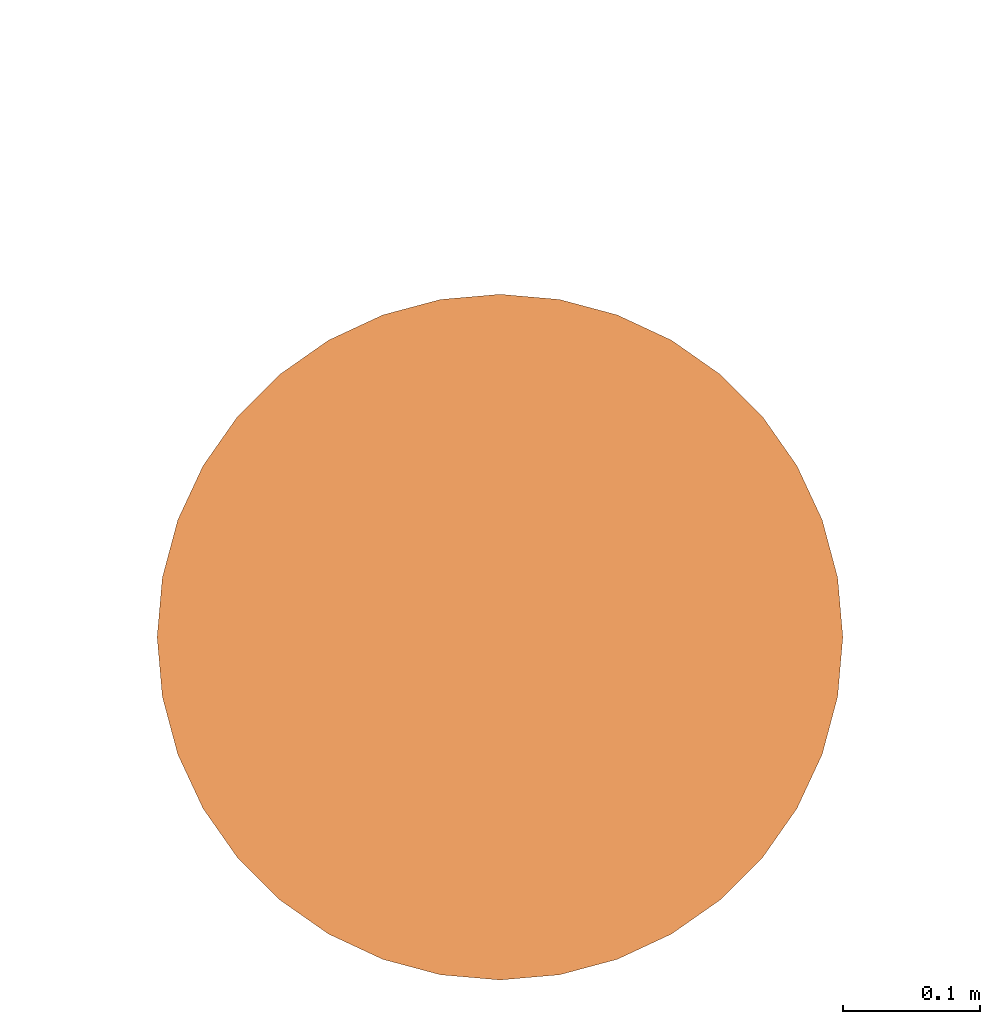
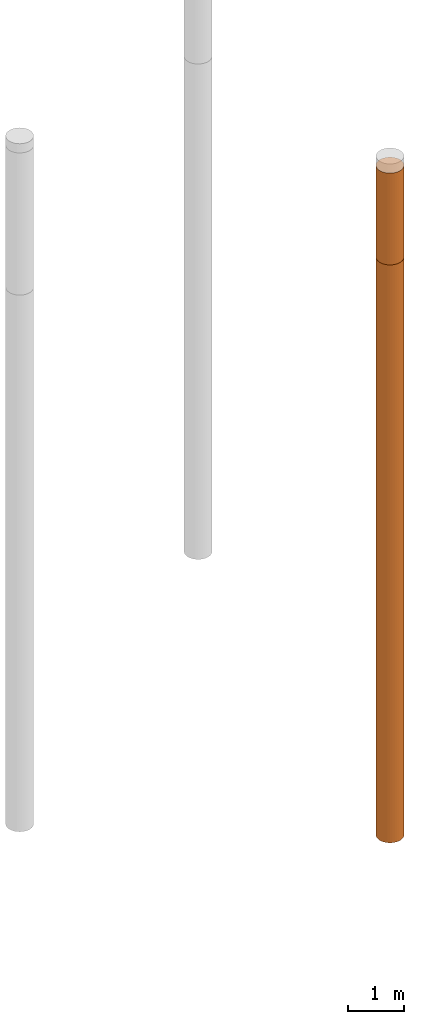
# One storey, part 3 of 8: 2 proxies.
"""IFC4 building model written with IfcOpenShell, lengths in metres."""

from ifc_helpers import new_model, entity, si_unit, converted_unit, frame, origin, place, context, subcontext, project, spatial, faceted_brep, material, element, save


model = new_model("IFC4")

# Units and contexts
model_context = context("Model", 3, precision=1e-05, world=origin())
body_context = subcontext(model_context, "Body", "Model", "MODEL_VIEW")
ifc_project = project(units=[si_unit("LENGTHUNIT", "METRE"), si_unit("AREAUNIT", "SQUARE_METRE"), si_unit("VOLUMEUNIT", "CUBIC_METRE"), converted_unit("PLANEANGLEUNIT", "DEGREE", entity("IfcPlaneAngleMeasure", 0.0174532925199433), si_unit("PLANEANGLEUNIT", "RADIAN"), dimensions=[0, 0, 0, 0, 0, 0, 0])], contexts=[model_context])

# Site, building, storey
site_placement = place(None, origin())
site = spatial("IfcSite", under=ifc_project, at=site_placement, CompositionType="ELEMENT")
building_placement = place(site_placement, origin())
building = spatial("IfcBuilding", under=site, at=building_placement, Name="Demo", CompositionType="ELEMENT")
storey_placement = place(building_placement, origin())
storey = spatial("IfcBuildingStorey", under=building, at=storey_placement, Name="Boden", CompositionType="ELEMENT", Elevation=0.0)

# Proxies
ifc_material_1 = material()
proxy_1_placement = place(storey_placement, frame((15.17, 5.39, -2.0)))
element("IfcBuildingElementProxy", 1, at=proxy_1_placement, inside=storey, material=ifc_material_1, Name="KB-02_Sand", PredefinedType="USERDEFINED", context=body_context, shape_type="Brep", body=[
    faceted_brep([(0.4962019382530525, 0.2934120444167338, 2.0), (0.5, 0.25, 2.0), (0.4962019382530525, 0.2065879555832671, 2.0), (0.4849231551964767, 0.1644949641685826, 2.0), (0.4665063509461107, 0.125, 2.0), (0.4415111107797439, 0.08930309757836494, 2.0), (0.4106969024216342, 0.05848888922025526, 2.0), (0.375, 0.0334936490538903, 2.0), (0.3355050358314166, 0.01507684480352327, 2.0), (0.2934120444167329, 0.003798061746948406, 2.0), (0.25, 0.0, 2.0), (0.2065879555832671, 0.003798061746948406, 2.0), (0.1644949641685835, 0.01507684480352327, 2.0), (0.125, 0.0334936490538903, 2.0), (0.08930309757836585, 0.05848888922025526, 2.0), (0.05848888922025617, 0.08930309757836494, 2.0), (0.0334936490538912, 0.125, 2.0), (0.01507684480352327, 0.1644949641685826, 2.0), (0.003798061746947497, 0.2065879555832671, 2.0), (0.0, 0.25, 2.0), (0.003798061746947497, 0.293412044416732, 2.0), (0.01507684480352327, 0.3355050358314166, 2.0), (0.03349364905388939, 0.375, 2.0), (0.05848888922025435, 0.4106969024216342, 2.0), (0.08930309757836404, 0.4415111107797439, 2.0), (0.125, 0.4665063509461097, 2.0), (0.1644949641685816, 0.4849231551964767, 2.0), (0.2065879555832671, 0.4962019382530516, 2.0), (0.25, 0.5, 2.0), (0.2934120444167311, 0.4962019382530525, 2.0), (0.3355050358314166, 0.4849231551964777, 2.0), (0.375, 0.4665063509461097, 2.0), (0.4106969024216342, 0.4415111107797448, 2.0), (0.4415111107797439, 0.410696902421636, 2.0), (0.4665063509461088, 0.3750000000000009, 2.0), (0.4849231551964767, 0.3355050358314184, 2.0), (0.5, 0.25, 0.0), (0.4962019382530525, 0.2934120444167338, 0.0), (0.4849231551964767, 0.3355050358314184, 0.0), (0.4665063509461088, 0.3750000000000009, 0.0), (0.4415111107797439, 0.4106969024216351, 0.0), (0.4106969024216342, 0.4415111107797448, 0.0), (0.375, 0.4665063509461097, 0.0), (0.3355050358314166, 0.4849231551964767, 0.0), (0.2934120444167311, 0.4962019382530516, 0.0), (0.25, 0.5, 0.0), (0.2065879555832671, 0.4962019382530516, 0.0), (0.1644949641685816, 0.4849231551964767, 0.0), (0.125, 0.4665063509461088, 0.0), (0.08930309757836404, 0.4415111107797439, 0.0), (0.05848888922025435, 0.4106969024216342, 0.0), (0.03349364905388939, 0.3749999999999991, 0.0), (0.01507684480352327, 0.3355050358314166, 0.0), (0.003798061746947497, 0.293412044416732, 0.0), (0.0, 0.2499999999999991, 0.0), (0.003798061746947497, 0.2065879555832671, 0.0), (0.01507684480352327, 0.1644949641685826, 0.0), (0.0334936490538912, 0.125, 0.0), (0.05848888922025617, 0.08930309757836494, 0.0), (0.08930309757836585, 0.05848888922025526, 0.0), (0.125, 0.0334936490538903, 0.0), (0.1644949641685835, 0.01507684480352236, 0.0), (0.2065879555832671, 0.003798061746947497, 0.0), (0.25, 0.0, 0.0), (0.2934120444167329, 0.003798061746947497, 0.0), (0.3355050358314166, 0.01507684480352236, 0.0), (0.375, 0.0334936490538903, 0.0), (0.4106969024216342, 0.05848888922025526, 0.0), (0.4415111107797439, 0.08930309757836494, 0.0), (0.4665063509461107, 0.125, 0.0), (0.4849231551964767, 0.1644949641685826, 0.0), (0.4962019382530525, 0.2065879555832671, 0.0), (0.5, 0.25, 2.0), (0.4962019382530525, 0.2934120444167338, 2.0), (0.4962019382530525, 0.2934120444167338, 0.0), (0.5, 0.25, 0.0), (0.4962019382530525, 0.2065879555832671, 2.0), (0.5, 0.25, 2.0), (0.5, 0.25, 0.0), (0.4962019382530525, 0.2065879555832671, 0.0), (0.4849231551964767, 0.1644949641685826, 2.0), (0.4962019382530525, 0.2065879555832671, 2.0), (0.4962019382530525, 0.2065879555832671, 0.0), (0.4849231551964767, 0.1644949641685826, 0.0), (0.4665063509461107, 0.125, 2.0), (0.4849231551964767, 0.1644949641685826, 2.0), (0.4849231551964767, 0.1644949641685826, 0.0), (0.4665063509461107, 0.125, 0.0), (0.4415111107797439, 0.08930309757836494, 2.0), (0.4665063509461107, 0.125, 2.0), (0.4665063509461107, 0.125, 0.0), (0.4415111107797439, 0.08930309757836494, 0.0), (0.4106969024216342, 0.05848888922025526, 2.0), (0.4415111107797439, 0.08930309757836494, 2.0), (0.4415111107797439, 0.08930309757836494, 0.0), (0.4106969024216342, 0.05848888922025526, 0.0), (0.375, 0.0334936490538903, 2.0), (0.4106969024216342, 0.05848888922025526, 2.0), (0.4106969024216342, 0.05848888922025526, 0.0), (0.375, 0.0334936490538903, 0.0), (0.3355050358314166, 0.01507684480352327, 2.0), (0.375, 0.0334936490538903, 2.0), (0.375, 0.0334936490538903, 0.0), (0.3355050358314166, 0.01507684480352236, 0.0), (0.2934120444167329, 0.003798061746948406, 2.0), (0.3355050358314166, 0.01507684480352327, 2.0), (0.3355050358314166, 0.01507684480352236, 0.0), (0.2934120444167329, 0.003798061746947497, 0.0), (0.25, 0.0, 2.0), (0.2934120444167329, 0.003798061746948406, 2.0), (0.2934120444167329, 0.003798061746947497, 0.0), (0.25, 0.0, 0.0), (0.2065879555832671, 0.003798061746948406, 2.0), (0.25, 0.0, 2.0), (0.25, 0.0, 0.0), (0.2065879555832671, 0.003798061746947497, 0.0), (0.1644949641685835, 0.01507684480352327, 2.0), (0.2065879555832671, 0.003798061746948406, 2.0), (0.2065879555832671, 0.003798061746947497, 0.0), (0.1644949641685835, 0.01507684480352236, 0.0), (0.125, 0.0334936490538903, 2.0), (0.1644949641685835, 0.01507684480352327, 2.0), (0.1644949641685835, 0.01507684480352236, 0.0), (0.125, 0.0334936490538903, 0.0), (0.08930309757836585, 0.05848888922025526, 2.0), (0.125, 0.0334936490538903, 2.0), (0.125, 0.0334936490538903, 0.0), (0.08930309757836585, 0.05848888922025526, 0.0), (0.05848888922025617, 0.08930309757836494, 2.0), (0.08930309757836585, 0.05848888922025526, 2.0), (0.08930309757836585, 0.05848888922025526, 0.0), (0.05848888922025617, 0.08930309757836494, 0.0), (0.0334936490538912, 0.125, 2.0), (0.05848888922025617, 0.08930309757836494, 2.0), (0.05848888922025617, 0.08930309757836494, 0.0), (0.0334936490538912, 0.125, 0.0), (0.01507684480352327, 0.1644949641685826, 2.0), (0.0334936490538912, 0.125, 2.0), (0.0334936490538912, 0.125, 0.0), (0.01507684480352327, 0.1644949641685826, 0.0), (0.003798061746947497, 0.2065879555832671, 2.0), (0.01507684480352327, 0.1644949641685826, 2.0), (0.01507684480352327, 0.1644949641685826, 0.0), (0.003798061746947497, 0.2065879555832671, 0.0), (0.0, 0.25, 2.0), (0.003798061746947497, 0.2065879555832671, 2.0), (0.003798061746947497, 0.2065879555832671, 0.0), (0.0, 0.2499999999999991, 0.0), (0.003798061746947497, 0.293412044416732, 2.0), (0.0, 0.25, 2.0), (0.0, 0.2499999999999991, 0.0), (0.003798061746947497, 0.293412044416732, 0.0), (0.01507684480352327, 0.3355050358314166, 2.0), (0.003798061746947497, 0.293412044416732, 2.0), (0.003798061746947497, 0.293412044416732, 0.0), (0.01507684480352327, 0.3355050358314166, 0.0), (0.03349364905388939, 0.375, 2.0), (0.01507684480352327, 0.3355050358314166, 2.0), (0.01507684480352327, 0.3355050358314166, 0.0), (0.03349364905388939, 0.3749999999999991, 0.0), (0.05848888922025435, 0.4106969024216342, 2.0), (0.03349364905388939, 0.375, 2.0), (0.03349364905388939, 0.3749999999999991, 0.0), (0.05848888922025435, 0.4106969024216342, 0.0), (0.08930309757836404, 0.4415111107797439, 2.0), (0.05848888922025435, 0.4106969024216342, 2.0), (0.05848888922025435, 0.4106969024216342, 0.0), (0.08930309757836404, 0.4415111107797439, 0.0), (0.125, 0.4665063509461097, 2.0), (0.08930309757836404, 0.4415111107797439, 2.0), (0.08930309757836404, 0.4415111107797439, 0.0), (0.125, 0.4665063509461088, 0.0), (0.1644949641685816, 0.4849231551964767, 2.0), (0.125, 0.4665063509461097, 2.0), (0.125, 0.4665063509461088, 0.0), (0.1644949641685816, 0.4849231551964767, 0.0), (0.2065879555832671, 0.4962019382530516, 2.0), (0.1644949641685816, 0.4849231551964767, 2.0), (0.1644949641685816, 0.4849231551964767, 0.0), (0.2065879555832671, 0.4962019382530516, 0.0), (0.25, 0.5, 2.0), (0.2065879555832671, 0.4962019382530516, 2.0), (0.2065879555832671, 0.4962019382530516, 0.0), (0.25, 0.5, 0.0), (0.2934120444167311, 0.4962019382530525, 2.0), (0.25, 0.5, 2.0), (0.25, 0.5, 0.0), (0.2934120444167311, 0.4962019382530516, 0.0), (0.3355050358314166, 0.4849231551964777, 2.0), (0.2934120444167311, 0.4962019382530525, 2.0), (0.2934120444167311, 0.4962019382530516, 0.0), (0.3355050358314166, 0.4849231551964767, 0.0), (0.375, 0.4665063509461097, 2.0), (0.3355050358314166, 0.4849231551964777, 2.0), (0.3355050358314166, 0.4849231551964767, 0.0), (0.375, 0.4665063509461097, 0.0), (0.4106969024216342, 0.4415111107797448, 2.0), (0.375, 0.4665063509461097, 2.0), (0.375, 0.4665063509461097, 0.0), (0.4106969024216342, 0.4415111107797448, 0.0), (0.4415111107797439, 0.410696902421636, 2.0), (0.4106969024216342, 0.4415111107797448, 2.0), (0.4106969024216342, 0.4415111107797448, 0.0), (0.4415111107797439, 0.4106969024216351, 0.0), (0.4665063509461088, 0.3750000000000009, 2.0), (0.4415111107797439, 0.410696902421636, 2.0), (0.4415111107797439, 0.4106969024216351, 0.0), (0.4665063509461088, 0.3750000000000009, 0.0), (0.4849231551964767, 0.3355050358314184, 2.0), (0.4665063509461088, 0.3750000000000009, 2.0), (0.4665063509461088, 0.3750000000000009, 0.0), (0.4849231551964767, 0.3355050358314184, 0.0), (0.4962019382530525, 0.2934120444167338, 2.0), (0.4849231551964767, 0.3355050358314184, 2.0), (0.4849231551964767, 0.3355050358314184, 0.0), (0.4962019382530525, 0.2934120444167338, 0.0)], [[[0, 1, 2, 3, 4, 5, 6, 7, 8, 9, 10, 11, 12, 13, 14, 15, 16, 17, 18, 19, 20, 21, 22, 23, 24, 25, 26, 27, 28, 29, 30, 31, 32, 33, 34, 35]], [[36, 37, 38, 39, 40, 41, 42, 43, 44, 45, 46, 47, 48, 49, 50, 51, 52, 53, 54, 55, 56, 57, 58, 59, 60, 61, 62, 63, 64, 65, 66, 67, 68, 69, 70, 71]], [[72, 73, 74, 75]], [[76, 77, 78, 79]], [[80, 81, 82, 83]], [[84, 85, 86, 87]], [[88, 89, 90, 91]], [[92, 93, 94, 95]], [[96, 97, 98, 99]], [[100, 101, 102, 103]], [[104, 105, 106, 107]], [[108, 109, 110, 111]], [[112, 113, 114, 115]], [[116, 117, 118, 119]], [[120, 121, 122, 123]], [[124, 125, 126, 127]], [[128, 129, 130, 131]], [[132, 133, 134, 135]], [[136, 137, 138, 139]], [[140, 141, 142, 143]], [[144, 145, 146, 147]], [[148, 149, 150, 151]], [[152, 153, 154, 155]], [[156, 157, 158, 159]], [[160, 161, 162, 163]], [[164, 165, 166, 167]], [[168, 169, 170, 171]], [[172, 173, 174, 175]], [[176, 177, 178, 179]], [[180, 181, 182, 183]], [[184, 185, 186, 187]], [[188, 189, 190, 191]], [[192, 193, 194, 195]], [[196, 197, 198, 199]], [[200, 201, 202, 203]], [[204, 205, 206, 207]], [[208, 209, 210, 211]], [[212, 213, 214, 215]]], orient=[[False], [False], [False], [False], [False], [False], [False], [False], [False], [False], [False], [False], [False], [False], [False], [False], [False], [False], [False], [False], [False], [False], [False], [False], [False], [False], [False], [False], [False], [False], [False], [False], [False], [False], [False], [False], [False], [False]]),
])
ifc_material_2 = material()
proxy_2_placement = place(storey_placement, frame((15.17, 5.389999999999998, -14.6)))
element("IfcBuildingElementProxy", 2, at=proxy_2_placement, inside=storey, material=ifc_material_2, Name="KB-02_Kies", PredefinedType="USERDEFINED", context=body_context, shape_type="Brep", body=[
    faceted_brep([(0.4962019382530525, 0.2934120444167356, 12.6), (0.5, 0.2500000000000018, 12.6), (0.4962019382530525, 0.2065879555832689, 12.6), (0.4849231551964767, 0.1644949641685844, 12.6), (0.4665063509461107, 0.1250000000000018, 12.6), (0.4415111107797439, 0.08930309757836676, 12.6), (0.4106969024216342, 0.05848888922025708, 12.6), (0.375, 0.03349364905389211, 12.6), (0.3355050358314166, 0.01507684480352509, 12.6), (0.2934120444167329, 0.003798061746950225, 12.6), (0.25, 1.818989403545857e-15, 12.6), (0.2065879555832671, 0.003798061746950225, 12.6), (0.1644949641685835, 0.01507684480352509, 12.6), (0.125, 0.03349364905389211, 12.6), (0.08930309757836585, 0.05848888922025708, 12.6), (0.05848888922025617, 0.08930309757836676, 12.6), (0.0334936490538912, 0.1250000000000018, 12.6), (0.01507684480352327, 0.1644949641685844, 12.6), (0.003798061746947497, 0.2065879555832689, 12.6), (0.0, 0.2500000000000018, 12.6), (0.003798061746947497, 0.2934120444167338, 12.6), (0.01507684480352327, 0.3355050358314184, 12.6), (0.03349364905388939, 0.3750000000000018, 12.6), (0.05848888922025435, 0.410696902421636, 12.6), (0.08930309757836404, 0.4415111107797456, 12.6), (0.125, 0.4665063509461115, 12.6), (0.1644949641685816, 0.4849231551964786, 12.6), (0.2065879555832671, 0.4962019382530534, 12.6), (0.25, 0.5000000000000018, 12.6), (0.2934120444167311, 0.4962019382530543, 12.6), (0.3355050358314166, 0.4849231551964795, 12.6), (0.375, 0.4665063509461115, 12.6), (0.4106969024216342, 0.4415111107797466, 12.6), (0.4415111107797439, 0.4106969024216378, 12.6), (0.4665063509461088, 0.3750000000000027, 12.6), (0.4849231551964767, 0.3355050358314202, 12.6), (0.5, 0.25, 0.0), (0.4962019382530525, 0.2934120444167338, 0.0), (0.4849231551964767, 0.3355050358314184, 0.0), (0.4665063509461088, 0.3750000000000009, 0.0), (0.4415111107797439, 0.410696902421636, 0.0), (0.4106969024216342, 0.4415111107797456, 0.0), (0.375, 0.4665063509461107, 0.0), (0.3355050358314166, 0.4849231551964777, 0.0), (0.2934120444167311, 0.4962019382530525, 0.0), (0.25, 0.5, 0.0), (0.2065879555832671, 0.4962019382530525, 0.0), (0.1644949641685816, 0.4849231551964767, 0.0), (0.125, 0.4665063509461097, 0.0), (0.08930309757836404, 0.4415111107797448, 0.0), (0.05848888922025435, 0.4106969024216351, 0.0), (0.03349364905388939, 0.375, 0.0), (0.01507684480352327, 0.3355050358314174, 0.0), (0.003798061746947497, 0.2934120444167329, 0.0), (0.0, 0.25, 0.0), (0.003798061746947497, 0.2065879555832671, 0.0), (0.01507684480352327, 0.1644949641685826, 0.0), (0.0334936490538912, 0.125, 0.0), (0.05848888922025617, 0.08930309757836494, 0.0), (0.08930309757836585, 0.05848888922025526, 0.0), (0.125, 0.0334936490538903, 0.0), (0.1644949641685835, 0.01507684480352327, 0.0), (0.2065879555832671, 0.003798061746948406, 0.0), (0.25, 0.0, 0.0), (0.2934120444167329, 0.003798061746948406, 0.0), (0.3355050358314166, 0.01507684480352327, 0.0), (0.375, 0.0334936490538903, 0.0), (0.4106969024216342, 0.05848888922025617, 0.0), (0.4415111107797439, 0.08930309757836585, 0.0), (0.4665063509461107, 0.125, 0.0), (0.4849231551964767, 0.1644949641685835, 0.0), (0.4962019382530525, 0.206587955583268, 0.0), (0.5, 0.2500000000000018, 12.6), (0.4962019382530525, 0.2934120444167356, 12.6), (0.4962019382530525, 0.2934120444167338, 0.0), (0.5, 0.25, 0.0), (0.4962019382530525, 0.2065879555832689, 12.6), (0.5, 0.2500000000000018, 12.6), (0.5, 0.25, 0.0), (0.4962019382530525, 0.206587955583268, 0.0), (0.4849231551964767, 0.1644949641685844, 12.6), (0.4962019382530525, 0.2065879555832689, 12.6), (0.4962019382530525, 0.206587955583268, 0.0), (0.4849231551964767, 0.1644949641685835, 0.0), (0.4665063509461107, 0.1250000000000018, 12.6), (0.4849231551964767, 0.1644949641685844, 12.6), (0.4849231551964767, 0.1644949641685835, 0.0), (0.4665063509461107, 0.125, 0.0), (0.4415111107797439, 0.08930309757836676, 12.6), (0.4665063509461107, 0.1250000000000018, 12.6), (0.4665063509461107, 0.125, 0.0), (0.4415111107797439, 0.08930309757836585, 0.0), (0.4106969024216342, 0.05848888922025708, 12.6), (0.4415111107797439, 0.08930309757836676, 12.6), (0.4415111107797439, 0.08930309757836585, 0.0), (0.4106969024216342, 0.05848888922025617, 0.0), (0.375, 0.03349364905389211, 12.6), (0.4106969024216342, 0.05848888922025708, 12.6), (0.4106969024216342, 0.05848888922025617, 0.0), (0.375, 0.0334936490538903, 0.0), (0.3355050358314166, 0.01507684480352509, 12.6), (0.375, 0.03349364905389211, 12.6), (0.375, 0.0334936490538903, 0.0), (0.3355050358314166, 0.01507684480352327, 0.0), (0.2934120444167329, 0.003798061746950225, 12.6), (0.3355050358314166, 0.01507684480352509, 12.6), (0.3355050358314166, 0.01507684480352327, 0.0), (0.2934120444167329, 0.003798061746948406, 0.0), (0.25, 1.818989403545857e-15, 12.6), (0.2934120444167329, 0.003798061746950225, 12.6), (0.2934120444167329, 0.003798061746948406, 0.0), (0.25, 0.0, 0.0), (0.2065879555832671, 0.003798061746950225, 12.6), (0.25, 1.818989403545857e-15, 12.6), (0.25, 0.0, 0.0), (0.2065879555832671, 0.003798061746948406, 0.0), (0.1644949641685835, 0.01507684480352509, 12.6), (0.2065879555832671, 0.003798061746950225, 12.6), (0.2065879555832671, 0.003798061746948406, 0.0), (0.1644949641685835, 0.01507684480352327, 0.0), (0.125, 0.03349364905389211, 12.6), (0.1644949641685835, 0.01507684480352509, 12.6), (0.1644949641685835, 0.01507684480352327, 0.0), (0.125, 0.0334936490538903, 0.0), (0.08930309757836585, 0.05848888922025708, 12.6), (0.125, 0.03349364905389211, 12.6), (0.125, 0.0334936490538903, 0.0), (0.08930309757836585, 0.05848888922025526, 0.0), (0.05848888922025617, 0.08930309757836676, 12.6), (0.08930309757836585, 0.05848888922025708, 12.6), (0.08930309757836585, 0.05848888922025526, 0.0), (0.05848888922025617, 0.08930309757836494, 0.0), (0.0334936490538912, 0.1250000000000018, 12.6), (0.05848888922025617, 0.08930309757836676, 12.6), (0.05848888922025617, 0.08930309757836494, 0.0), (0.0334936490538912, 0.125, 0.0), (0.01507684480352327, 0.1644949641685844, 12.6), (0.0334936490538912, 0.1250000000000018, 12.6), (0.0334936490538912, 0.125, 0.0), (0.01507684480352327, 0.1644949641685826, 0.0), (0.003798061746947497, 0.2065879555832689, 12.6), (0.01507684480352327, 0.1644949641685844, 12.6), (0.01507684480352327, 0.1644949641685826, 0.0), (0.003798061746947497, 0.2065879555832671, 0.0), (0.0, 0.2500000000000018, 12.6), (0.003798061746947497, 0.2065879555832689, 12.6), (0.003798061746947497, 0.2065879555832671, 0.0), (0.0, 0.25, 0.0), (0.003798061746947497, 0.2934120444167338, 12.6), (0.0, 0.2500000000000018, 12.6), (0.0, 0.25, 0.0), (0.003798061746947497, 0.2934120444167329, 0.0), (0.01507684480352327, 0.3355050358314184, 12.6), (0.003798061746947497, 0.2934120444167338, 12.6), (0.003798061746947497, 0.2934120444167329, 0.0), (0.01507684480352327, 0.3355050358314174, 0.0), (0.03349364905388939, 0.3750000000000018, 12.6), (0.01507684480352327, 0.3355050358314184, 12.6), (0.01507684480352327, 0.3355050358314174, 0.0), (0.03349364905388939, 0.375, 0.0), (0.05848888922025435, 0.410696902421636, 12.6), (0.03349364905388939, 0.3750000000000018, 12.6), (0.03349364905388939, 0.375, 0.0), (0.05848888922025435, 0.4106969024216351, 0.0), (0.08930309757836404, 0.4415111107797456, 12.6), (0.05848888922025435, 0.410696902421636, 12.6), (0.05848888922025435, 0.4106969024216351, 0.0), (0.08930309757836404, 0.4415111107797448, 0.0), (0.125, 0.4665063509461115, 12.6), (0.08930309757836404, 0.4415111107797456, 12.6), (0.08930309757836404, 0.4415111107797448, 0.0), (0.125, 0.4665063509461097, 0.0), (0.1644949641685816, 0.4849231551964786, 12.6), (0.125, 0.4665063509461115, 12.6), (0.125, 0.4665063509461097, 0.0), (0.1644949641685816, 0.4849231551964767, 0.0), (0.2065879555832671, 0.4962019382530534, 12.6), (0.1644949641685816, 0.4849231551964786, 12.6), (0.1644949641685816, 0.4849231551964767, 0.0), (0.2065879555832671, 0.4962019382530525, 0.0), (0.25, 0.5000000000000018, 12.6), (0.2065879555832671, 0.4962019382530534, 12.6), (0.2065879555832671, 0.4962019382530525, 0.0), (0.25, 0.5, 0.0), (0.2934120444167311, 0.4962019382530543, 12.6), (0.25, 0.5000000000000018, 12.6), (0.25, 0.5, 0.0), (0.2934120444167311, 0.4962019382530525, 0.0), (0.3355050358314166, 0.4849231551964795, 12.6), (0.2934120444167311, 0.4962019382530543, 12.6), (0.2934120444167311, 0.4962019382530525, 0.0), (0.3355050358314166, 0.4849231551964777, 0.0), (0.375, 0.4665063509461115, 12.6), (0.3355050358314166, 0.4849231551964795, 12.6), (0.3355050358314166, 0.4849231551964777, 0.0), (0.375, 0.4665063509461107, 0.0), (0.4106969024216342, 0.4415111107797466, 12.6), (0.375, 0.4665063509461115, 12.6), (0.375, 0.4665063509461107, 0.0), (0.4106969024216342, 0.4415111107797456, 0.0), (0.4415111107797439, 0.4106969024216378, 12.6), (0.4106969024216342, 0.4415111107797466, 12.6), (0.4106969024216342, 0.4415111107797456, 0.0), (0.4415111107797439, 0.410696902421636, 0.0), (0.4665063509461088, 0.3750000000000027, 12.6), (0.4415111107797439, 0.4106969024216378, 12.6), (0.4415111107797439, 0.410696902421636, 0.0), (0.4665063509461088, 0.3750000000000009, 0.0), (0.4849231551964767, 0.3355050358314202, 12.6), (0.4665063509461088, 0.3750000000000027, 12.6), (0.4665063509461088, 0.3750000000000009, 0.0), (0.4849231551964767, 0.3355050358314184, 0.0), (0.4962019382530525, 0.2934120444167356, 12.6), (0.4849231551964767, 0.3355050358314202, 12.6), (0.4849231551964767, 0.3355050358314184, 0.0), (0.4962019382530525, 0.2934120444167338, 0.0)], [[[0, 1, 2, 3, 4, 5, 6, 7, 8, 9, 10, 11, 12, 13, 14, 15, 16, 17, 18, 19, 20, 21, 22, 23, 24, 25, 26, 27, 28, 29, 30, 31, 32, 33, 34, 35]], [[36, 37, 38, 39, 40, 41, 42, 43, 44, 45, 46, 47, 48, 49, 50, 51, 52, 53, 54, 55, 56, 57, 58, 59, 60, 61, 62, 63, 64, 65, 66, 67, 68, 69, 70, 71]], [[72, 73, 74, 75]], [[76, 77, 78, 79]], [[80, 81, 82, 83]], [[84, 85, 86, 87]], [[88, 89, 90, 91]], [[92, 93, 94, 95]], [[96, 97, 98, 99]], [[100, 101, 102, 103]], [[104, 105, 106, 107]], [[108, 109, 110, 111]], [[112, 113, 114, 115]], [[116, 117, 118, 119]], [[120, 121, 122, 123]], [[124, 125, 126, 127]], [[128, 129, 130, 131]], [[132, 133, 134, 135]], [[136, 137, 138, 139]], [[140, 141, 142, 143]], [[144, 145, 146, 147]], [[148, 149, 150, 151]], [[152, 153, 154, 155]], [[156, 157, 158, 159]], [[160, 161, 162, 163]], [[164, 165, 166, 167]], [[168, 169, 170, 171]], [[172, 173, 174, 175]], [[176, 177, 178, 179]], [[180, 181, 182, 183]], [[184, 185, 186, 187]], [[188, 189, 190, 191]], [[192, 193, 194, 195]], [[196, 197, 198, 199]], [[200, 201, 202, 203]], [[204, 205, 206, 207]], [[208, 209, 210, 211]], [[212, 213, 214, 215]]], orient=[[False], [False], [False], [False], [False], [False], [False], [False], [False], [False], [False], [False], [False], [False], [False], [False], [False], [False], [False], [False], [False], [False], [False], [False], [False], [False], [False], [False], [False], [False], [False], [False], [False], [False], [False], [False], [False], [False]]),
])

save(model, "model.ifc")
